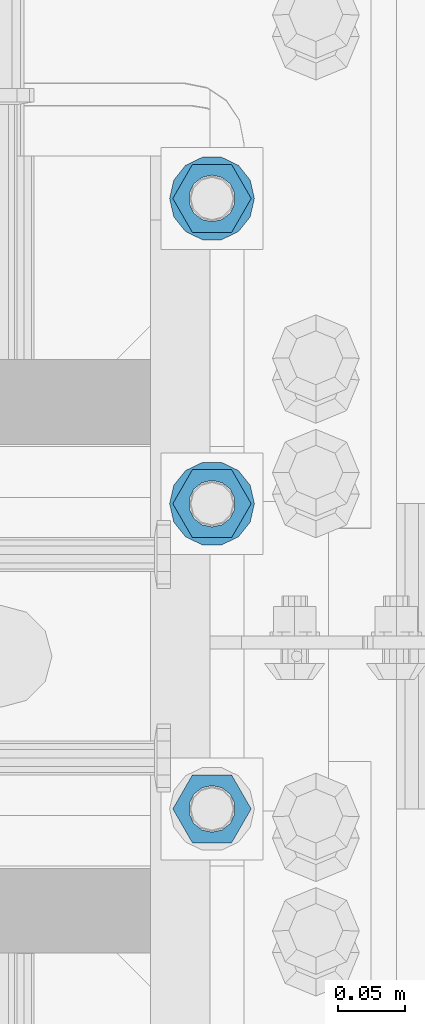
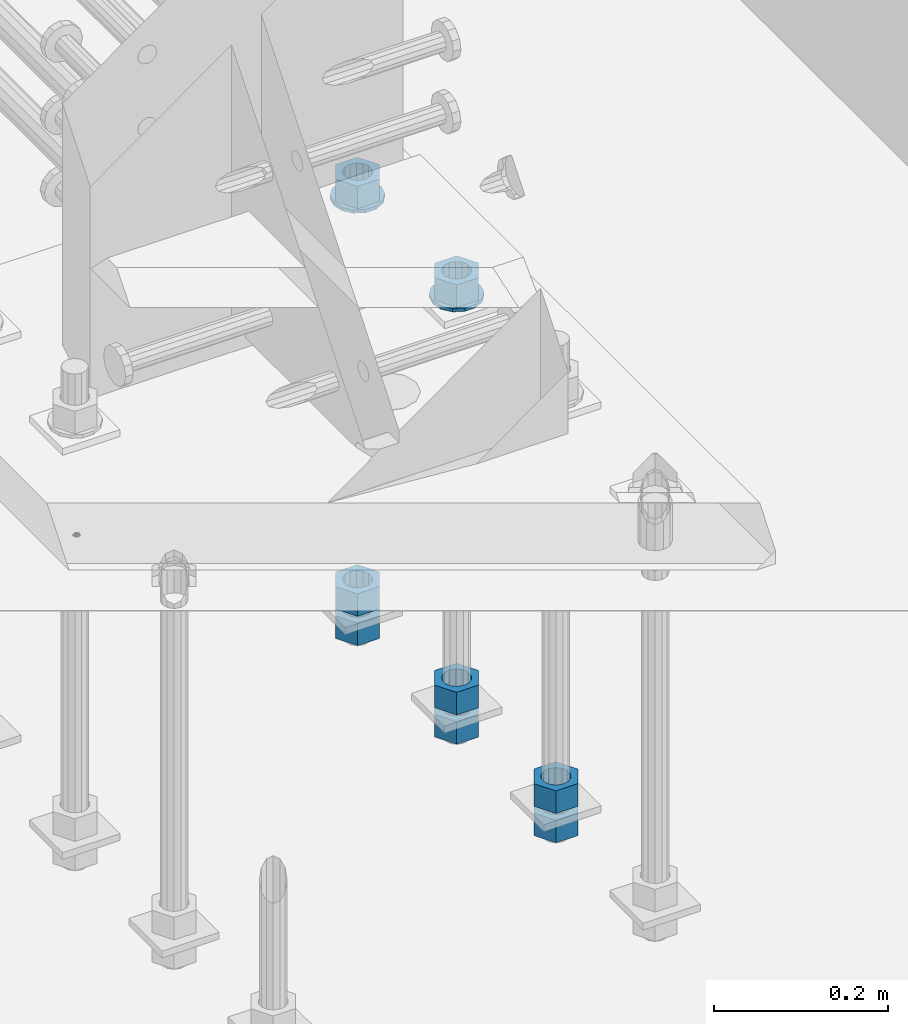
# One storey, part 1012 of 1763: 10 columns, 1 element without a shape of its own.
"""IFC2X3 building model written with IfcOpenShell, lengths in millimetres."""

from ifc_helpers import new_model, si_unit, frame, origin_with_axes, place, context, subcontext, project, spatial, faceted_brep, material, type_object, element, aggregate, save


model = new_model("IFC2X3")

# Units and contexts
model_context = context("Model", 3, precision=1e-05, world=origin_with_axes())
body_context = subcontext(model_context, "Body", "Model", "MODEL_VIEW")
ifc_project = project(units=[si_unit("LENGTHUNIT", "METRE", prefix="MILLI"), si_unit("AREAUNIT", "SQUARE_METRE"), si_unit("VOLUMEUNIT", "CUBIC_METRE"), si_unit("MASSUNIT", "GRAM", prefix="KILO"), si_unit("TIMEUNIT", "SECOND"), si_unit("PLANEANGLEUNIT", "RADIAN"), si_unit("SOLIDANGLEUNIT", "STERADIAN"), si_unit("THERMODYNAMICTEMPERATUREUNIT", "DEGREE_CELSIUS"), si_unit("LUMINOUSINTENSITYUNIT", "LUMEN")], contexts=[model_context])

# Site, building, storey
site_placement = place(None, origin_with_axes())
site = spatial("IfcSite", under=ifc_project, at=site_placement, CompositionType="ELEMENT")
building_placement = place(site_placement, origin_with_axes())
building = spatial("IfcBuilding", under=site, at=building_placement, Name="Undefined", CompositionType="ELEMENT")
storey_placement = place(building_placement, origin_with_axes())
storey = spatial("IfcBuildingStorey", under=building, at=storey_placement, Name="Undefined", CompositionType="ELEMENT", Elevation=0.0)

# Assembly, columns
assembly_placement = place(storey_placement, origin_with_axes())
assembly = element("IfcElementAssembly", 1, at=assembly_placement, inside=storey, Name="TEMPLATE", AssemblyPlace="NOTDEFINED", PredefinedType="RIGID_FRAME")
ifc_material_1 = material(Name="STEEL/A563")
column_type_1 = type_object("IfcColumnType", Name="1-1/4_HEAVY_HEX_NUT", PredefinedType="NOTDEFINED")
column_1_placement = place(assembly_placement, frame((-23773.8372736984, 342.899999999998, 3384.55), z_axis=(0.0, 1.0, 0.0), x_axis=(0.0, 0.0, -1.0)))
column_1 = element("IfcColumn", 2, at=column_1_placement, type_object=column_type_1, material=ifc_material_1, Name="NUT", ObjectType="1-1/4_HEAVY_HEX_NUT", context=body_context, shape_type="Brep", body=[
    faceted_brep([(0.0, -29.3700008392334, 0.0), (0.0, -14.6800003051758, -25.4300003051758), (31.75, -14.6800003051758, -25.4300003051758), (31.75, -29.3700008392334, 0.0), (0.0, 14.6800003051758, -25.4300003051758), (31.75, 14.6800003051758, -25.4300003051758), (0.0, 29.3700008392334, 0.0), (31.75, 29.3700008392334, 0.0), (0.0, 14.6800003051758, 25.4300003051758), (31.75, 14.6800003051758, 25.4300003051758), (0.0, -14.6800003051758, 25.4300003051758), (31.75, -14.6800003051758, 25.4300003051758), (0.0, 0.0, 17.4599990844727), (0.0, 7.57560968776022, 15.730915608714), (31.75, 7.57560968775942, 15.7309156087145), (31.75, 0.0, 17.4599990844727), (0.0, 13.6507769681037, 10.8861313696252), (31.75, 13.6507769681048, 10.8861313696314), (0.0, 17.0222404541215, 3.88521530314756), (31.75, 17.02224045412, 3.88521530315316), (0.0, 17.0222404541215, -3.88521530314756), (31.75, 17.02224045412, -3.88521530315332), (0.0, 13.6507769681037, -10.8861313696252), (31.75, 13.6507769681048, -10.8861313696316), (0.0, 7.57560968776022, -15.730915608714), (31.75, 7.57560968775942, -15.7309156087146), (0.0, 0.0, -17.4599990844727), (31.75, 0.0, -17.4599990844727), (0.0, -7.57560968776022, -15.730915608714), (31.75, -7.57560968775942, -15.7309156087145), (0.0, -13.6507769681037, -10.8861313696252), (31.75, -13.6507769681048, -10.8861313696314), (0.0, -17.0222404541215, -3.88521530314756), (31.75, -17.02224045412, -3.88521530315316), (0.0, -17.0222404541215, 3.88521530314756), (31.75, -17.02224045412, 3.88521530315332), (0.0, -13.6507769681037, 10.8861313696252), (31.75, -13.6507769681048, 10.8861313696316), (0.0, -7.57560968776022, 15.730915608714), (31.75, -7.57560968775942, 15.7309156087146)], [[[0, 1, 2, 3]], [[1, 4, 5, 2]], [[4, 6, 7, 5]], [[6, 8, 9, 7]], [[8, 10, 11, 9]], [[10, 0, 3, 11]], [[12, 13, 14, 15]], [[13, 16, 17, 14]], [[16, 18, 19, 17]], [[18, 20, 21, 19]], [[20, 22, 23, 21]], [[22, 24, 25, 23]], [[24, 26, 27, 25]], [[26, 28, 29, 27]], [[28, 30, 31, 29]], [[30, 32, 33, 31]], [[32, 34, 35, 33]], [[34, 36, 37, 35]], [[36, 38, 39, 37]], [[38, 12, 15, 39]], [[5, 7, 9, 11, 3, 2], [17, 19, 21, 23, 25, 27, 29, 31, 33, 35, 37, 39, 15, 14]], [[10, 8, 6, 4, 1, 0], [38, 36, 34, 32, 30, 28, 26, 24, 22, 20, 18, 16, 13, 12]]]),
])
column_2_placement = place(assembly_placement, frame((-23773.8372736984, 342.899999999998, 3343.275), z_axis=(0.0, 1.0, 0.0), x_axis=(0.0, 0.0, -1.0)))
column_2 = element("IfcColumn", 3, at=column_2_placement, type_object=column_type_1, material=ifc_material_1, Name="NUT", ObjectType="1-1/4_HEAVY_HEX_NUT", context=body_context, shape_type="Brep", body=[
    faceted_brep([(0.0, -29.3700008392334, 0.0), (0.0, -14.6800003051758, -25.4300003051758), (31.75, -14.6800003051758, -25.4300003051758), (31.75, -29.3700008392334, 0.0), (0.0, 14.6800003051758, -25.4300003051758), (31.75, 14.6800003051758, -25.4300003051758), (0.0, 29.3700008392334, 0.0), (31.75, 29.3700008392334, 0.0), (0.0, 14.6800003051758, 25.4300003051758), (31.75, 14.6800003051758, 25.4300003051758), (0.0, -14.6800003051758, 25.4300003051758), (31.75, -14.6800003051758, 25.4300003051758), (0.0, 0.0, 17.4599990844727), (0.0, 7.57560968776022, 15.730915608714), (31.75, 7.57560968775942, 15.7309156087145), (31.75, 0.0, 17.4599990844727), (0.0, 13.6507769681037, 10.8861313696252), (31.75, 13.6507769681048, 10.8861313696314), (0.0, 17.0222404541215, 3.88521530314756), (31.75, 17.02224045412, 3.88521530315316), (0.0, 17.0222404541215, -3.88521530314756), (31.75, 17.02224045412, -3.88521530315332), (0.0, 13.6507769681037, -10.8861313696252), (31.75, 13.6507769681048, -10.8861313696316), (0.0, 7.57560968776022, -15.730915608714), (31.75, 7.57560968775942, -15.7309156087146), (0.0, 0.0, -17.4599990844727), (31.75, 0.0, -17.4599990844727), (0.0, -7.57560968776022, -15.730915608714), (31.75, -7.57560968775942, -15.7309156087145), (0.0, -13.6507769681037, -10.8861313696252), (31.75, -13.6507769681048, -10.8861313696314), (0.0, -17.0222404541215, -3.88521530314756), (31.75, -17.02224045412, -3.88521530315316), (0.0, -17.0222404541215, 3.88521530314756), (31.75, -17.02224045412, 3.88521530315332), (0.0, -13.6507769681037, 10.8861313696252), (31.75, -13.6507769681048, 10.8861313696316), (0.0, -7.57560968776022, 15.730915608714), (31.75, -7.57560968775942, 15.7309156087146)], [[[0, 1, 2, 3]], [[1, 4, 5, 2]], [[4, 6, 7, 5]], [[6, 8, 9, 7]], [[8, 10, 11, 9]], [[10, 0, 3, 11]], [[12, 13, 14, 15]], [[13, 16, 17, 14]], [[16, 18, 19, 17]], [[18, 20, 21, 19]], [[20, 22, 23, 21]], [[22, 24, 25, 23]], [[24, 26, 27, 25]], [[26, 28, 29, 27]], [[28, 30, 31, 29]], [[30, 32, 33, 31]], [[32, 34, 35, 33]], [[34, 36, 37, 35]], [[36, 38, 39, 37]], [[38, 12, 15, 39]], [[5, 7, 9, 11, 3, 2], [17, 19, 21, 23, 25, 27, 29, 31, 33, 35, 37, 39, 15, 14]], [[10, 8, 6, 4, 1, 0], [38, 36, 34, 32, 30, 28, 26, 24, 22, 20, 18, 16, 13, 12]]]),
])
column_3_placement = place(assembly_placement, frame((-23773.8372736984, 571.499999999998, 3957.6375), z_axis=(0.0, 1.0, 0.0), x_axis=(0.0, 0.0, -1.0)))
column_3 = element("IfcColumn", 4, at=column_3_placement, type_object=column_type_1, material=ifc_material_1, Name="NUT", ObjectType="1-1/4_HEAVY_HEX_NUT", context=body_context, shape_type="Brep", body=[
    faceted_brep([(0.0, -29.3700008392334, 0.0), (0.0, -14.6800003051758, -25.4300003051758), (31.75, -14.6800003051758, -25.4300003051758), (31.75, -29.3700008392334, 0.0), (0.0, 14.6800003051758, -25.4300003051758), (31.75, 14.6800003051758, -25.4300003051758), (0.0, 29.3700008392334, 0.0), (31.75, 29.3700008392334, 0.0), (0.0, 14.6800003051758, 25.4300003051758), (31.75, 14.6800003051758, 25.4300003051758), (0.0, -14.6800003051758, 25.4300003051758), (31.75, -14.6800003051758, 25.4300003051758), (0.0, 0.0, 17.4599990844727), (0.0, 7.57560968776022, 15.730915608714), (31.75, 7.57560968775942, 15.7309156087145), (31.75, 0.0, 17.4599990844727), (0.0, 13.6507769681037, 10.8861313696252), (31.75, 13.6507769681048, 10.8861313696314), (0.0, 17.0222404541215, 3.88521530314756), (31.75, 17.02224045412, 3.88521530315316), (0.0, 17.0222404541215, -3.88521530314756), (31.75, 17.02224045412, -3.88521530315332), (0.0, 13.6507769681037, -10.8861313696252), (31.75, 13.6507769681048, -10.8861313696316), (0.0, 7.57560968776022, -15.730915608714), (31.75, 7.57560968775942, -15.7309156087146), (0.0, 0.0, -17.4599990844727), (31.75, 0.0, -17.4599990844727), (0.0, -7.57560968776022, -15.730915608714), (31.75, -7.57560968775942, -15.7309156087145), (0.0, -13.6507769681037, -10.8861313696252), (31.75, -13.6507769681048, -10.8861313696314), (0.0, -17.0222404541215, -3.88521530314756), (31.75, -17.02224045412, -3.88521530315316), (0.0, -17.0222404541215, 3.88521530314756), (31.75, -17.02224045412, 3.88521530315332), (0.0, -13.6507769681037, 10.8861313696252), (31.75, -13.6507769681048, 10.8861313696316), (0.0, -7.57560968776022, 15.730915608714), (31.75, -7.57560968775942, 15.7309156087146)], [[[0, 1, 2, 3]], [[1, 4, 5, 2]], [[4, 6, 7, 5]], [[6, 8, 9, 7]], [[8, 10, 11, 9]], [[10, 0, 3, 11]], [[12, 13, 14, 15]], [[13, 16, 17, 14]], [[16, 18, 19, 17]], [[18, 20, 21, 19]], [[20, 22, 23, 21]], [[22, 24, 25, 23]], [[24, 26, 27, 25]], [[26, 28, 29, 27]], [[28, 30, 31, 29]], [[30, 32, 33, 31]], [[32, 34, 35, 33]], [[34, 36, 37, 35]], [[36, 38, 39, 37]], [[38, 12, 15, 39]], [[5, 7, 9, 11, 3, 2], [17, 19, 21, 23, 25, 27, 29, 31, 33, 35, 37, 39, 15, 14]], [[10, 8, 6, 4, 1, 0], [38, 36, 34, 32, 30, 28, 26, 24, 22, 20, 18, 16, 13, 12]]]),
])
column_4_placement = place(assembly_placement, frame((-23773.8372736984, 571.499999999998, 3384.55), z_axis=(0.0, 1.0, 0.0), x_axis=(0.0, 0.0, -1.0)))
column_4 = element("IfcColumn", 5, at=column_4_placement, type_object=column_type_1, material=ifc_material_1, Name="NUT", ObjectType="1-1/4_HEAVY_HEX_NUT", context=body_context, shape_type="Brep", body=[
    faceted_brep([(0.0, -29.3700008392334, 0.0), (0.0, -14.6800003051758, -25.4300003051758), (31.75, -14.6800003051758, -25.4300003051758), (31.75, -29.3700008392334, 0.0), (0.0, 14.6800003051758, -25.4300003051758), (31.75, 14.6800003051758, -25.4300003051758), (0.0, 29.3700008392334, 0.0), (31.75, 29.3700008392334, 0.0), (0.0, 14.6800003051758, 25.4300003051758), (31.75, 14.6800003051758, 25.4300003051758), (0.0, -14.6800003051758, 25.4300003051758), (31.75, -14.6800003051758, 25.4300003051758), (0.0, 0.0, 17.4599990844727), (0.0, 7.57560968776022, 15.730915608714), (31.75, 7.57560968775942, 15.7309156087145), (31.75, 0.0, 17.4599990844727), (0.0, 13.6507769681037, 10.8861313696252), (31.75, 13.6507769681048, 10.8861313696314), (0.0, 17.0222404541215, 3.88521530314756), (31.75, 17.02224045412, 3.88521530315316), (0.0, 17.0222404541215, -3.88521530314756), (31.75, 17.02224045412, -3.88521530315332), (0.0, 13.6507769681037, -10.8861313696252), (31.75, 13.6507769681048, -10.8861313696316), (0.0, 7.57560968776022, -15.730915608714), (31.75, 7.57560968775942, -15.7309156087146), (0.0, 0.0, -17.4599990844727), (31.75, 0.0, -17.4599990844727), (0.0, -7.57560968776022, -15.730915608714), (31.75, -7.57560968775942, -15.7309156087145), (0.0, -13.6507769681037, -10.8861313696252), (31.75, -13.6507769681048, -10.8861313696314), (0.0, -17.0222404541215, -3.88521530314756), (31.75, -17.02224045412, -3.88521530315316), (0.0, -17.0222404541215, 3.88521530314756), (31.75, -17.02224045412, 3.88521530315332), (0.0, -13.6507769681037, 10.8861313696252), (31.75, -13.6507769681048, 10.8861313696316), (0.0, -7.57560968776022, 15.730915608714), (31.75, -7.57560968775942, 15.7309156087146)], [[[0, 1, 2, 3]], [[1, 4, 5, 2]], [[4, 6, 7, 5]], [[6, 8, 9, 7]], [[8, 10, 11, 9]], [[10, 0, 3, 11]], [[12, 13, 14, 15]], [[13, 16, 17, 14]], [[16, 18, 19, 17]], [[18, 20, 21, 19]], [[20, 22, 23, 21]], [[22, 24, 25, 23]], [[24, 26, 27, 25]], [[26, 28, 29, 27]], [[28, 30, 31, 29]], [[30, 32, 33, 31]], [[32, 34, 35, 33]], [[34, 36, 37, 35]], [[36, 38, 39, 37]], [[38, 12, 15, 39]], [[5, 7, 9, 11, 3, 2], [17, 19, 21, 23, 25, 27, 29, 31, 33, 35, 37, 39, 15, 14]], [[10, 8, 6, 4, 1, 0], [38, 36, 34, 32, 30, 28, 26, 24, 22, 20, 18, 16, 13, 12]]]),
])
column_5_placement = place(assembly_placement, frame((-23773.8372736984, 571.499999999998, 3343.275), z_axis=(0.0, 1.0, 0.0), x_axis=(0.0, 0.0, -1.0)))
column_5 = element("IfcColumn", 6, at=column_5_placement, type_object=column_type_1, material=ifc_material_1, Name="NUT", ObjectType="1-1/4_HEAVY_HEX_NUT", context=body_context, shape_type="Brep", body=[
    faceted_brep([(0.0, -29.3700008392334, 0.0), (0.0, -14.6800003051758, -25.4300003051758), (31.75, -14.6800003051758, -25.4300003051758), (31.75, -29.3700008392334, 0.0), (0.0, 14.6800003051758, -25.4300003051758), (31.75, 14.6800003051758, -25.4300003051758), (0.0, 29.3700008392334, 0.0), (31.75, 29.3700008392334, 0.0), (0.0, 14.6800003051758, 25.4300003051758), (31.75, 14.6800003051758, 25.4300003051758), (0.0, -14.6800003051758, 25.4300003051758), (31.75, -14.6800003051758, 25.4300003051758), (0.0, 0.0, 17.4599990844727), (0.0, 7.57560968776022, 15.730915608714), (31.75, 7.57560968775942, 15.7309156087145), (31.75, 0.0, 17.4599990844727), (0.0, 13.6507769681037, 10.8861313696252), (31.75, 13.6507769681048, 10.8861313696314), (0.0, 17.0222404541215, 3.88521530314756), (31.75, 17.02224045412, 3.88521530315316), (0.0, 17.0222404541215, -3.88521530314756), (31.75, 17.02224045412, -3.88521530315332), (0.0, 13.6507769681037, -10.8861313696252), (31.75, 13.6507769681048, -10.8861313696316), (0.0, 7.57560968776022, -15.730915608714), (31.75, 7.57560968775942, -15.7309156087146), (0.0, 0.0, -17.4599990844727), (31.75, 0.0, -17.4599990844727), (0.0, -7.57560968776022, -15.730915608714), (31.75, -7.57560968775942, -15.7309156087145), (0.0, -13.6507769681037, -10.8861313696252), (31.75, -13.6507769681048, -10.8861313696314), (0.0, -17.0222404541215, -3.88521530314756), (31.75, -17.02224045412, -3.88521530315316), (0.0, -17.0222404541215, 3.88521530314756), (31.75, -17.02224045412, 3.88521530315332), (0.0, -13.6507769681037, 10.8861313696252), (31.75, -13.6507769681048, 10.8861313696316), (0.0, -7.57560968776022, 15.730915608714), (31.75, -7.57560968775942, 15.7309156087146)], [[[0, 1, 2, 3]], [[1, 4, 5, 2]], [[4, 6, 7, 5]], [[6, 8, 9, 7]], [[8, 10, 11, 9]], [[10, 0, 3, 11]], [[12, 13, 14, 15]], [[13, 16, 17, 14]], [[16, 18, 19, 17]], [[18, 20, 21, 19]], [[20, 22, 23, 21]], [[22, 24, 25, 23]], [[24, 26, 27, 25]], [[26, 28, 29, 27]], [[28, 30, 31, 29]], [[30, 32, 33, 31]], [[32, 34, 35, 33]], [[34, 36, 37, 35]], [[36, 38, 39, 37]], [[38, 12, 15, 39]], [[5, 7, 9, 11, 3, 2], [17, 19, 21, 23, 25, 27, 29, 31, 33, 35, 37, 39, 15, 14]], [[10, 8, 6, 4, 1, 0], [38, 36, 34, 32, 30, 28, 26, 24, 22, 20, 18, 16, 13, 12]]]),
])
column_6_placement = place(assembly_placement, frame((-23773.8372736984, 800.099999999998, 3957.6375), z_axis=(0.0, 1.0, 0.0), x_axis=(0.0, 0.0, -1.0)))
column_6 = element("IfcColumn", 7, at=column_6_placement, type_object=column_type_1, material=ifc_material_1, Name="NUT", ObjectType="1-1/4_HEAVY_HEX_NUT", context=body_context, shape_type="Brep", body=[
    faceted_brep([(0.0, -29.3700008392334, 0.0), (0.0, -14.6800003051758, -25.4300003051758), (31.75, -14.6800003051758, -25.4300003051758), (31.75, -29.3700008392334, 0.0), (0.0, 14.6800003051758, -25.4300003051758), (31.75, 14.6800003051758, -25.4300003051758), (0.0, 29.3700008392334, 0.0), (31.75, 29.3700008392334, 0.0), (0.0, 14.6800003051758, 25.4300003051758), (31.75, 14.6800003051758, 25.4300003051758), (0.0, -14.6800003051758, 25.4300003051758), (31.75, -14.6800003051758, 25.4300003051758), (0.0, 0.0, 17.4599990844727), (0.0, 7.57560968776022, 15.730915608714), (31.75, 7.57560968775942, 15.7309156087145), (31.75, 0.0, 17.4599990844727), (0.0, 13.6507769681037, 10.8861313696252), (31.75, 13.6507769681048, 10.8861313696314), (0.0, 17.0222404541215, 3.88521530314756), (31.75, 17.02224045412, 3.88521530315316), (0.0, 17.0222404541215, -3.88521530314756), (31.75, 17.02224045412, -3.88521530315332), (0.0, 13.6507769681037, -10.8861313696252), (31.75, 13.6507769681048, -10.8861313696316), (0.0, 7.57560968776022, -15.730915608714), (31.75, 7.57560968775942, -15.7309156087146), (0.0, 0.0, -17.4599990844727), (31.75, 0.0, -17.4599990844727), (0.0, -7.57560968776022, -15.730915608714), (31.75, -7.57560968775942, -15.7309156087145), (0.0, -13.6507769681037, -10.8861313696252), (31.75, -13.6507769681048, -10.8861313696314), (0.0, -17.0222404541215, -3.88521530314756), (31.75, -17.02224045412, -3.88521530315316), (0.0, -17.0222404541215, 3.88521530314756), (31.75, -17.02224045412, 3.88521530315332), (0.0, -13.6507769681037, 10.8861313696252), (31.75, -13.6507769681048, 10.8861313696316), (0.0, -7.57560968776022, 15.730915608714), (31.75, -7.57560968775942, 15.7309156087146)], [[[0, 1, 2, 3]], [[1, 4, 5, 2]], [[4, 6, 7, 5]], [[6, 8, 9, 7]], [[8, 10, 11, 9]], [[10, 0, 3, 11]], [[12, 13, 14, 15]], [[13, 16, 17, 14]], [[16, 18, 19, 17]], [[18, 20, 21, 19]], [[20, 22, 23, 21]], [[22, 24, 25, 23]], [[24, 26, 27, 25]], [[26, 28, 29, 27]], [[28, 30, 31, 29]], [[30, 32, 33, 31]], [[32, 34, 35, 33]], [[34, 36, 37, 35]], [[36, 38, 39, 37]], [[38, 12, 15, 39]], [[5, 7, 9, 11, 3, 2], [17, 19, 21, 23, 25, 27, 29, 31, 33, 35, 37, 39, 15, 14]], [[10, 8, 6, 4, 1, 0], [38, 36, 34, 32, 30, 28, 26, 24, 22, 20, 18, 16, 13, 12]]]),
])
column_7_placement = place(assembly_placement, frame((-23773.8372736984, 800.099999999998, 3384.55), z_axis=(0.0, 1.0, 0.0), x_axis=(0.0, 0.0, -1.0)))
column_7 = element("IfcColumn", 8, at=column_7_placement, type_object=column_type_1, material=ifc_material_1, Name="NUT", ObjectType="1-1/4_HEAVY_HEX_NUT", context=body_context, shape_type="Brep", body=[
    faceted_brep([(0.0, -29.3700008392334, 0.0), (0.0, -14.6800003051758, -25.4300003051758), (31.75, -14.6800003051758, -25.4300003051758), (31.75, -29.3700008392334, 0.0), (0.0, 14.6800003051758, -25.4300003051758), (31.75, 14.6800003051758, -25.4300003051758), (0.0, 29.3700008392334, 0.0), (31.75, 29.3700008392334, 0.0), (0.0, 14.6800003051758, 25.4300003051758), (31.75, 14.6800003051758, 25.4300003051758), (0.0, -14.6800003051758, 25.4300003051758), (31.75, -14.6800003051758, 25.4300003051758), (0.0, 0.0, 17.4599990844727), (0.0, 7.57560968776022, 15.730915608714), (31.75, 7.57560968775942, 15.7309156087145), (31.75, 0.0, 17.4599990844727), (0.0, 13.6507769681037, 10.8861313696252), (31.75, 13.6507769681048, 10.8861313696314), (0.0, 17.0222404541215, 3.88521530314756), (31.75, 17.02224045412, 3.88521530315316), (0.0, 17.0222404541215, -3.88521530314756), (31.75, 17.02224045412, -3.88521530315332), (0.0, 13.6507769681037, -10.8861313696252), (31.75, 13.6507769681048, -10.8861313696316), (0.0, 7.57560968776022, -15.730915608714), (31.75, 7.57560968775942, -15.7309156087146), (0.0, 0.0, -17.4599990844727), (31.75, 0.0, -17.4599990844727), (0.0, -7.57560968776022, -15.730915608714), (31.75, -7.57560968775942, -15.7309156087145), (0.0, -13.6507769681037, -10.8861313696252), (31.75, -13.6507769681048, -10.8861313696314), (0.0, -17.0222404541215, -3.88521530314756), (31.75, -17.02224045412, -3.88521530315316), (0.0, -17.0222404541215, 3.88521530314756), (31.75, -17.02224045412, 3.88521530315332), (0.0, -13.6507769681037, 10.8861313696252), (31.75, -13.6507769681048, 10.8861313696316), (0.0, -7.57560968776022, 15.730915608714), (31.75, -7.57560968775942, 15.7309156087146)], [[[0, 1, 2, 3]], [[1, 4, 5, 2]], [[4, 6, 7, 5]], [[6, 8, 9, 7]], [[8, 10, 11, 9]], [[10, 0, 3, 11]], [[12, 13, 14, 15]], [[13, 16, 17, 14]], [[16, 18, 19, 17]], [[18, 20, 21, 19]], [[20, 22, 23, 21]], [[22, 24, 25, 23]], [[24, 26, 27, 25]], [[26, 28, 29, 27]], [[28, 30, 31, 29]], [[30, 32, 33, 31]], [[32, 34, 35, 33]], [[34, 36, 37, 35]], [[36, 38, 39, 37]], [[38, 12, 15, 39]], [[5, 7, 9, 11, 3, 2], [17, 19, 21, 23, 25, 27, 29, 31, 33, 35, 37, 39, 15, 14]], [[10, 8, 6, 4, 1, 0], [38, 36, 34, 32, 30, 28, 26, 24, 22, 20, 18, 16, 13, 12]]]),
])
column_8_placement = place(assembly_placement, frame((-23773.8372736984, 800.099999999998, 3343.275), z_axis=(0.0, 1.0, 0.0), x_axis=(0.0, 0.0, -1.0)))
column_8 = element("IfcColumn", 9, at=column_8_placement, type_object=column_type_1, material=ifc_material_1, Name="NUT", ObjectType="1-1/4_HEAVY_HEX_NUT", context=body_context, shape_type="Brep", body=[
    faceted_brep([(0.0, -29.3700008392334, 0.0), (0.0, -14.6800003051758, -25.4300003051758), (31.75, -14.6800003051758, -25.4300003051758), (31.75, -29.3700008392334, 0.0), (0.0, 14.6800003051758, -25.4300003051758), (31.75, 14.6800003051758, -25.4300003051758), (0.0, 29.3700008392334, 0.0), (31.75, 29.3700008392334, 0.0), (0.0, 14.6800003051758, 25.4300003051758), (31.75, 14.6800003051758, 25.4300003051758), (0.0, -14.6800003051758, 25.4300003051758), (31.75, -14.6800003051758, 25.4300003051758), (0.0, 0.0, 17.4599990844727), (0.0, 7.57560968776022, 15.730915608714), (31.75, 7.57560968775942, 15.7309156087145), (31.75, 0.0, 17.4599990844727), (0.0, 13.6507769681037, 10.8861313696252), (31.75, 13.6507769681048, 10.8861313696314), (0.0, 17.0222404541215, 3.88521530314756), (31.75, 17.02224045412, 3.88521530315316), (0.0, 17.0222404541215, -3.88521530314756), (31.75, 17.02224045412, -3.88521530315332), (0.0, 13.6507769681037, -10.8861313696252), (31.75, 13.6507769681048, -10.8861313696316), (0.0, 7.57560968776022, -15.730915608714), (31.75, 7.57560968775942, -15.7309156087146), (0.0, 0.0, -17.4599990844727), (31.75, 0.0, -17.4599990844727), (0.0, -7.57560968776022, -15.730915608714), (31.75, -7.57560968775942, -15.7309156087145), (0.0, -13.6507769681037, -10.8861313696252), (31.75, -13.6507769681048, -10.8861313696314), (0.0, -17.0222404541215, -3.88521530314756), (31.75, -17.02224045412, -3.88521530315316), (0.0, -17.0222404541215, 3.88521530314756), (31.75, -17.02224045412, 3.88521530315332), (0.0, -13.6507769681037, 10.8861313696252), (31.75, -13.6507769681048, 10.8861313696316), (0.0, -7.57560968776022, 15.730915608714), (31.75, -7.57560968775942, 15.7309156087146)], [[[0, 1, 2, 3]], [[1, 4, 5, 2]], [[4, 6, 7, 5]], [[6, 8, 9, 7]], [[8, 10, 11, 9]], [[10, 0, 3, 11]], [[12, 13, 14, 15]], [[13, 16, 17, 14]], [[16, 18, 19, 17]], [[18, 20, 21, 19]], [[20, 22, 23, 21]], [[22, 24, 25, 23]], [[24, 26, 27, 25]], [[26, 28, 29, 27]], [[28, 30, 31, 29]], [[30, 32, 33, 31]], [[32, 34, 35, 33]], [[34, 36, 37, 35]], [[36, 38, 39, 37]], [[38, 12, 15, 39]], [[5, 7, 9, 11, 3, 2], [17, 19, 21, 23, 25, 27, 29, 31, 33, 35, 37, 39, 15, 14]], [[10, 8, 6, 4, 1, 0], [38, 36, 34, 32, 30, 28, 26, 24, 22, 20, 18, 16, 13, 12]]]),
])
ifc_material_2 = material(Name="STEEL/F436")
column_type_2 = type_object("IfcColumnType", Name="1-1/4_WASHER", PredefinedType="NOTDEFINED")
column_9_placement = place(assembly_placement, frame((-23773.8372736984, 571.499999999998, 3925.8875), z_axis=(0.0, 1.0, 0.0), x_axis=(0.0, 0.0, -1.0)))
column_9 = element("IfcColumn", 10, at=column_9_placement, type_object=column_type_2, material=ifc_material_2, Name="WASHER", ObjectType="1-1/4_WASHER", context=body_context, shape_type="Brep", body=[
    faceted_brep([(-4.54747350886464e-13, -31.7499999999964, 0.0), (0.0, -28.6057615559002, -13.7758087169827), (4.76249999999982, -28.6057615559002, -13.7758087169827), (4.76249999999982, -31.75, 0.0), (0.0, -19.795801209013, -24.8231495683602), (4.76249999999982, -19.795801209013, -24.8231495683602), (0.0, -7.06503965311276, -30.9539612117732), (4.76249999999982, -7.06503965311276, -30.9539612117732), (0.0, 7.06503965311276, -30.9539612117732), (4.76249999999982, 7.06503965311276, -30.9539612117732), (0.0, 19.7958012090166, -24.8231495683602), (4.76249999999982, 19.7958012090166, -24.8231495683602), (0.0, 28.6057615559039, -13.7758087169827), (4.76249999999982, 28.6057615559039, -13.7758087169827), (-5.91171556152403e-12, 31.7499999999891, 0.0), (4.76249999999982, 31.75, 0.0), (0.0, 28.6057615559002, 13.7758087169827), (4.76249999999982, 28.6057615559002, 13.7758087169827), (0.0, 19.795801209013, 24.8231495683602), (4.76249999999982, 19.795801209013, 24.8231495683602), (0.0, 7.06503965311276, 30.9539612117731), (4.76249999999982, 7.06503965311276, 30.9539612117731), (0.0, -7.06503965311276, 30.9539612117731), (4.76249999999982, -7.06503965311276, 30.9539612117731), (0.0, -19.7958012090166, 24.8231495683602), (4.76249999999982, -19.7958012090166, 24.8231495683602), (0.0, -28.6057615559039, 13.7758087169827), (4.76249999999982, -28.6057615559039, 13.7758087169827), (0.0, 0.0, 17.4599990844727), (0.0, 7.57560968776022, 15.730915608714), (4.76249999999982, 7.57560968775942, 15.7309156087145), (4.76249999999982, 0.0, 17.4599990844727), (0.0, 13.6507769681037, 10.8861313696252), (4.76249999999982, 13.6507769681048, 10.8861313696314), (0.0, 17.0222404541215, 3.88521530314756), (4.76249999999982, 17.02224045412, 3.88521530315316), (0.0, 17.0222404541215, -3.88521530314756), (4.76249999999982, 17.02224045412, -3.88521530315332), (0.0, 13.6507769681037, -10.8861313696252), (4.76249999999982, 13.6507769681048, -10.8861313696316), (0.0, 7.57560968776022, -15.730915608714), (4.76249999999982, 7.57560968775942, -15.7309156087146), (0.0, 0.0, -17.4599990844727), (4.76249999999982, 0.0, -17.4599990844727), (0.0, -7.57560968776022, -15.730915608714), (4.76249999999982, -7.57560968775942, -15.7309156087145), (0.0, -13.6507769681037, -10.8861313696252), (4.76249999999982, -13.6507769681048, -10.8861313696314), (0.0, -17.0222404541215, -3.88521530314756), (4.76249999999982, -17.02224045412, -3.88521530315316), (0.0, -17.0222404541215, 3.88521530314756), (4.76249999999982, -17.02224045412, 3.88521530315332), (0.0, -13.6507769681037, 10.8861313696252), (4.76249999999982, -13.6507769681048, 10.8861313696316), (0.0, -7.57560968776022, 15.730915608714), (4.76249999999982, -7.57560968775942, 15.7309156087146)], [[[0, 1, 2, 3]], [[1, 4, 5, 2]], [[4, 6, 7, 5]], [[6, 8, 9, 7]], [[8, 10, 11, 9]], [[10, 12, 13, 11]], [[12, 14, 15, 13]], [[14, 16, 17, 15]], [[16, 18, 19, 17]], [[18, 20, 21, 19]], [[20, 22, 23, 21]], [[22, 24, 25, 23]], [[24, 26, 27, 25]], [[26, 0, 3, 27]], [[28, 29, 30, 31]], [[29, 32, 33, 30]], [[32, 34, 35, 33]], [[34, 36, 37, 35]], [[36, 38, 39, 37]], [[38, 40, 41, 39]], [[40, 42, 43, 41]], [[42, 44, 45, 43]], [[44, 46, 47, 45]], [[46, 48, 49, 47]], [[48, 50, 51, 49]], [[50, 52, 53, 51]], [[52, 54, 55, 53]], [[54, 28, 31, 55]], [[5, 7, 9, 11, 13, 15, 17, 19, 21, 23, 25, 27, 3, 2], [33, 35, 37, 39, 41, 43, 45, 47, 49, 51, 53, 55, 31, 30]], [[26, 24, 22, 20, 18, 16, 14, 12, 10, 8, 6, 4, 1, 0], [54, 52, 50, 48, 46, 44, 42, 40, 38, 36, 34, 32, 29, 28]]]),
])
column_10_placement = place(assembly_placement, frame((-23773.8372736984, 800.099999999998, 3925.8875), z_axis=(0.0, 1.0, 0.0), x_axis=(0.0, 0.0, -1.0)))
column_10 = element("IfcColumn", 11, at=column_10_placement, type_object=column_type_2, material=ifc_material_2, Name="WASHER", ObjectType="1-1/4_WASHER", context=body_context, shape_type="Brep", body=[
    faceted_brep([(-4.54747350886464e-13, -31.7499999999964, 0.0), (0.0, -28.6057615559002, -13.7758087169827), (4.76249999999982, -28.6057615559002, -13.7758087169827), (4.76249999999982, -31.75, 0.0), (0.0, -19.795801209013, -24.8231495683602), (4.76249999999982, -19.795801209013, -24.8231495683602), (0.0, -7.06503965311276, -30.9539612117732), (4.76249999999982, -7.06503965311276, -30.9539612117732), (0.0, 7.06503965311276, -30.9539612117732), (4.76249999999982, 7.06503965311276, -30.9539612117732), (0.0, 19.7958012090166, -24.8231495683602), (4.76249999999982, 19.7958012090166, -24.8231495683602), (0.0, 28.6057615559039, -13.7758087169827), (4.76249999999982, 28.6057615559039, -13.7758087169827), (-5.91171556152403e-12, 31.7499999999891, 0.0), (4.76249999999982, 31.75, 0.0), (0.0, 28.6057615559002, 13.7758087169827), (4.76249999999982, 28.6057615559002, 13.7758087169827), (0.0, 19.795801209013, 24.8231495683602), (4.76249999999982, 19.795801209013, 24.8231495683602), (0.0, 7.06503965311276, 30.9539612117731), (4.76249999999982, 7.06503965311276, 30.9539612117731), (0.0, -7.06503965311276, 30.9539612117731), (4.76249999999982, -7.06503965311276, 30.9539612117731), (0.0, -19.7958012090166, 24.8231495683602), (4.76249999999982, -19.7958012090166, 24.8231495683602), (0.0, -28.6057615559039, 13.7758087169827), (4.76249999999982, -28.6057615559039, 13.7758087169827), (0.0, 0.0, 17.4599990844727), (0.0, 7.57560968776022, 15.730915608714), (4.76249999999982, 7.57560968775942, 15.7309156087145), (4.76249999999982, 0.0, 17.4599990844727), (0.0, 13.6507769681037, 10.8861313696252), (4.76249999999982, 13.6507769681048, 10.8861313696314), (0.0, 17.0222404541215, 3.88521530314756), (4.76249999999982, 17.02224045412, 3.88521530315316), (0.0, 17.0222404541215, -3.88521530314756), (4.76249999999982, 17.02224045412, -3.88521530315332), (0.0, 13.6507769681037, -10.8861313696252), (4.76249999999982, 13.6507769681048, -10.8861313696316), (0.0, 7.57560968776022, -15.730915608714), (4.76249999999982, 7.57560968775942, -15.7309156087146), (0.0, 0.0, -17.4599990844727), (4.76249999999982, 0.0, -17.4599990844727), (0.0, -7.57560968776022, -15.730915608714), (4.76249999999982, -7.57560968775942, -15.7309156087145), (0.0, -13.6507769681037, -10.8861313696252), (4.76249999999982, -13.6507769681048, -10.8861313696314), (0.0, -17.0222404541215, -3.88521530314756), (4.76249999999982, -17.02224045412, -3.88521530315316), (0.0, -17.0222404541215, 3.88521530314756), (4.76249999999982, -17.02224045412, 3.88521530315332), (0.0, -13.6507769681037, 10.8861313696252), (4.76249999999982, -13.6507769681048, 10.8861313696316), (0.0, -7.57560968776022, 15.730915608714), (4.76249999999982, -7.57560968775942, 15.7309156087146)], [[[0, 1, 2, 3]], [[1, 4, 5, 2]], [[4, 6, 7, 5]], [[6, 8, 9, 7]], [[8, 10, 11, 9]], [[10, 12, 13, 11]], [[12, 14, 15, 13]], [[14, 16, 17, 15]], [[16, 18, 19, 17]], [[18, 20, 21, 19]], [[20, 22, 23, 21]], [[22, 24, 25, 23]], [[24, 26, 27, 25]], [[26, 0, 3, 27]], [[28, 29, 30, 31]], [[29, 32, 33, 30]], [[32, 34, 35, 33]], [[34, 36, 37, 35]], [[36, 38, 39, 37]], [[38, 40, 41, 39]], [[40, 42, 43, 41]], [[42, 44, 45, 43]], [[44, 46, 47, 45]], [[46, 48, 49, 47]], [[48, 50, 51, 49]], [[50, 52, 53, 51]], [[52, 54, 55, 53]], [[54, 28, 31, 55]], [[5, 7, 9, 11, 13, 15, 17, 19, 21, 23, 25, 27, 3, 2], [33, 35, 37, 39, 41, 43, 45, 47, 49, 51, 53, 55, 31, 30]], [[26, 24, 22, 20, 18, 16, 14, 12, 10, 8, 6, 4, 1, 0], [54, 52, 50, 48, 46, 44, 42, 40, 38, 36, 34, 32, 29, 28]]]),
])
aggregate(assembly, [column_1, column_2, column_3, column_9, column_4, column_5, column_6, column_10, column_7, column_8])

save(model, "model.ifc")
